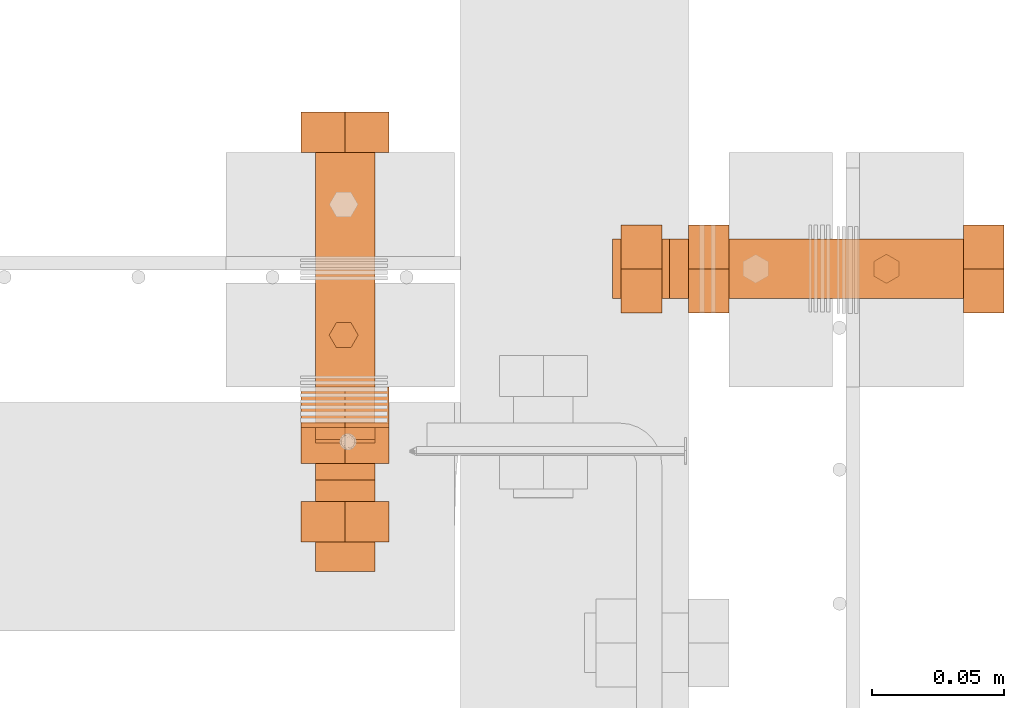
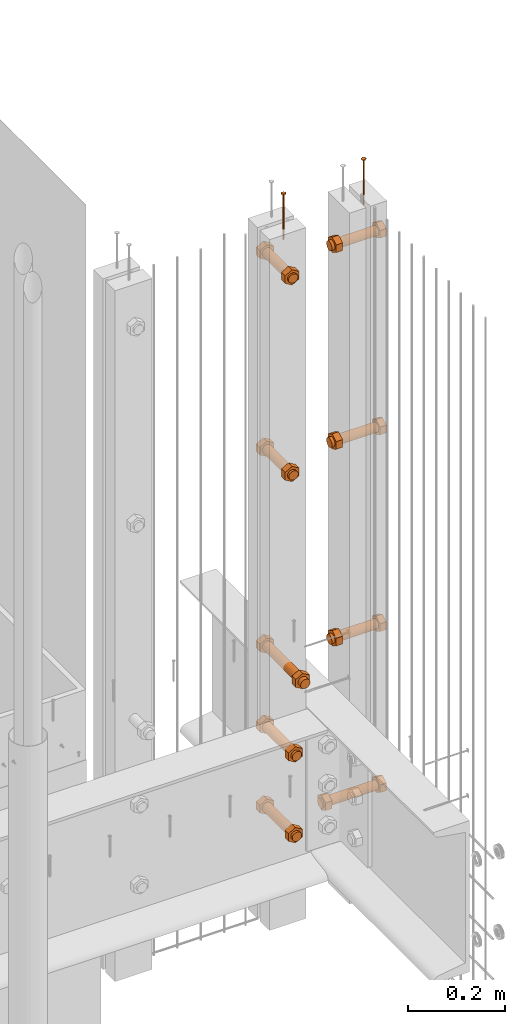
# One storey, part 24 of 44: 11 proxies.
"""IFC4 building model written with IfcOpenShell, lengths in feet."""

from ifc_helpers import new_model, entity, si_unit, converted_unit, derived_unit, direction, frame, frame_2d, origin, place, context, subcontext, project, spatial, polyline, circle, outline, extrude, source, transform, mapped, material, type_object, type_shapes, element, save


model = new_model("IFC4")

# Units and contexts
model_context = context("Model", 3, precision=0.0001, world=origin(), true_north=direction((6.12303176911189e-17, 1.0)))
body_context = subcontext(model_context, "Body", "Model", "MODEL_VIEW")
ifc_project = project(units=[converted_unit("LENGTHUNIT", "FOOT", entity("IfcRatioMeasure", 0.3048), si_unit("LENGTHUNIT", "METRE"), dimensions=[1, 0, 0, 0, 0, 0, 0]), converted_unit("AREAUNIT", "SQUARE FOOT", entity("IfcRatioMeasure", 0.09290304), si_unit("AREAUNIT", "SQUARE_METRE"), dimensions=[2, 0, 0, 0, 0, 0, 0]), converted_unit("VOLUMEUNIT", "CUBIC FOOT", entity("IfcRatioMeasure", 0.028316846592), si_unit("VOLUMEUNIT", "CUBIC_METRE"), dimensions=[3, 0, 0, 0, 0, 0, 0]), converted_unit("PLANEANGLEUNIT", "DEGREE", entity("IfcRatioMeasure", 0.0174532925199433), si_unit("PLANEANGLEUNIT", "RADIAN"), dimensions=[0, 0, 0, 0, 0, 0, 0]), si_unit("MASSUNIT", "GRAM", prefix="KILO"), derived_unit("MASSDENSITYUNIT", [(si_unit("MASSUNIT", "GRAM", prefix="KILO"), 1), (si_unit("LENGTHUNIT", "METRE"), -3)]), derived_unit("MOMENTOFINERTIAUNIT", [(si_unit("LENGTHUNIT", "METRE"), 4)]), si_unit("TIMEUNIT", "SECOND"), si_unit("FREQUENCYUNIT", "HERTZ"), si_unit("THERMODYNAMICTEMPERATUREUNIT", "DEGREE_CELSIUS"), derived_unit("THERMALTRANSMITTANCEUNIT", [(si_unit("MASSUNIT", "GRAM", prefix="KILO"), 1), (si_unit("THERMODYNAMICTEMPERATUREUNIT", "KELVIN"), -1), (si_unit("TIMEUNIT", "SECOND"), -3)]), derived_unit("VOLUMETRICFLOWRATEUNIT", [(si_unit("LENGTHUNIT", "METRE"), 3), (si_unit("TIMEUNIT", "SECOND"), -1)]), si_unit("ELECTRICCURRENTUNIT", "AMPERE"), si_unit("ELECTRICVOLTAGEUNIT", "VOLT"), si_unit("POWERUNIT", "WATT"), si_unit("FORCEUNIT", "NEWTON"), si_unit("ILLUMINANCEUNIT", "LUX"), si_unit("LUMINOUSFLUXUNIT", "LUMEN"), si_unit("LUMINOUSINTENSITYUNIT", "CANDELA"), derived_unit("USERDEFINED", [(si_unit("MASSUNIT", "GRAM", prefix="KILO"), -1), (si_unit("LENGTHUNIT", "METRE"), -2), (si_unit("TIMEUNIT", "SECOND"), 3), (si_unit("LUMINOUSFLUXUNIT", "LUMEN"), 1)]), derived_unit("LINEARVELOCITYUNIT", [(si_unit("LENGTHUNIT", "METRE"), 1), (si_unit("TIMEUNIT", "SECOND"), -1)]), si_unit("PRESSUREUNIT", "PASCAL"), derived_unit("USERDEFINED", [(si_unit("LENGTHUNIT", "METRE"), -2), (si_unit("MASSUNIT", "GRAM", prefix="KILO"), 1), (si_unit("TIMEUNIT", "SECOND"), -2)]), derived_unit("LINEARFORCEUNIT", [(si_unit("MASSUNIT", "GRAM", prefix="KILO"), 1), (si_unit("LENGTHUNIT", "METRE"), 1), (si_unit("TIMEUNIT", "SECOND"), -2), (si_unit("LENGTHUNIT", "METRE"), -1)]), derived_unit("PLANARFORCEUNIT", [(si_unit("MASSUNIT", "GRAM", prefix="KILO"), 1), (si_unit("LENGTHUNIT", "METRE"), 1), (si_unit("TIMEUNIT", "SECOND"), -2), (si_unit("LENGTHUNIT", "METRE"), -2)])], contexts=[model_context])

# Site, building, storey
site_placement = place(None, origin())
site = spatial("IfcSite", under=ifc_project, at=site_placement, CompositionType="ELEMENT")
building_placement = place(site_placement, origin())
building = spatial("IfcBuilding", under=site, at=building_placement, CompositionType="ELEMENT")
storey_placement = place(building_placement, origin())
storey = spatial("IfcBuildingStorey", under=building, at=storey_placement, CompositionType="ELEMENT", Elevation=0.0)

# Proxies
ifc_material_1 = material(Name="EXPOSED LAG BOLTS", Category="Materials")
building_element_proxy_type_1 = type_object("IfcBuildingElementProxyType", PredefinedType="NOTDEFINED", material=ifc_material_1)
shared_shape_1 = source(origin(), body_context, "Body", "SweptSolid", [
    extrude(outline(polyline([(-0.0315738428463097, -0.0546875000000126), (0.0315738428462861, -0.0546875000000126), (0.0631476856926272, 0.0), (0.0315738428463528, 0.0546874999999876), (-0.0315738428463294, 0.0546874999999873), (-0.0631476856926271, 0.0), (-0.0315738428463097, -0.0546875000000126)])), frame((0.0, 0.0, -0.425455729167055), z_axis=(0.0, 0.0, 1.0), x_axis=(0.866025403784438, -0.500000000000001, 0.0)), (0.0, 0.0, 1.0), 0.0504557291666657),
    extrude(outline(polyline([(-0.0315738428463175, -0.054687500000008), (0.0315738428463173, -0.054687500000008), (0.0631476856926152, 0.0), (0.0315738428462743, 0.0546875000000329), (-0.0315738428462739, 0.0546875000000332), (-0.0631476856926154, 0.0), (-0.0315738428463175, -0.054687500000008)])), frame((0.0, 0.0, 0.0), z_axis=(0.0, 0.0, 1.0), x_axis=(0.0, -1.0, 0.0)), (0.0, 0.0, 1.0), 0.0504557291666658),
    extrude(circle(Radius=0.0372721354166667, at=frame_2d((-3.16883874077982e-18, -6.0214796149918e-17), x_axis=(1.0, 0.0))), frame((0.0, 0.0, -0.436376009077554), z_axis=(0.0, 0.0, 1.0), x_axis=(0.0, 1.0, 0.0)), (0.0, 0.0, 1.0), 0.436376009077548),
])
type_shapes(building_element_proxy_type_1, [shared_shape_1])
proxy_1_placement = place(storey_placement, frame((1494.63395604586, 4.90491114741325, 8.9706002862303), z_axis=(1.0, 0.0, 0.0), x_axis=(0.0, 1.0, 0.0)))
element("IfcBuildingElementProxy", 1, at=proxy_1_placement, inside=storey, type_object=building_element_proxy_type_1, material=ifc_material_1, PredefinedType="NOTDEFINED", context=body_context, shape_type="MappedRepresentation", body=[
    mapped(shared_shape_1, transform((0.0, 0.0, 0.0), scale=1.0)),
])
ifc_material_2 = material(Name="TRIM HEAD SCREWS AT RAILING - EXTERIOR GRADE", Category="Materials")
building_element_proxy_type_2 = type_object("IfcBuildingElementProxyType", PredefinedType="NOTDEFINED", material=ifc_material_2)
cartesian_point_1 = entity("IfcCartesianPoint", [0.0, -0.00455729166677975, -0.374999999999898])
vertex_point_1 = entity("IfcVertexPoint", cartesian_point_1)
cartesian_point_2 = entity("IfcCartesianPoint", [0.0, 0.00455729166667765, -0.374999999999898])
vertex_point_2 = entity("IfcVertexPoint", cartesian_point_2)
cartesian_point_3 = entity("IfcCartesianPoint", [0.0, 0.0, -0.374999999999898])
ifc_direction_1 = entity("IfcDirection", [0.0, 0.0, 1.0])
ifc_direction_2 = entity("IfcDirection", [0.0, 1.0, 0.0])
edge_curve_1 = entity("IfcEdgeCurve", vertex_point_1, vertex_point_2, entity("IfcTrimmedCurve", entity("IfcCircle", entity("IfcAxis2Placement3D", cartesian_point_3, ifc_direction_1, ifc_direction_2), 0.0045572916667287), [cartesian_point_1], [cartesian_point_2], True, "CARTESIAN"), True)
vertex_point_3 = entity("IfcVertexPoint", cartesian_point_3)
ifc_direction_3 = entity("IfcDirection", [0.0, -1.0, 0.0])
edge_curve_2 = entity("IfcEdgeCurve", vertex_point_2, vertex_point_3, entity("IfcTrimmedCurve", entity("IfcLine", cartesian_point_2, entity("IfcVector", ifc_direction_3, 1.0)), [cartesian_point_2], [cartesian_point_3], True, "CARTESIAN"), True)
edge_curve_3 = entity("IfcEdgeCurve", vertex_point_3, vertex_point_1, entity("IfcTrimmedCurve", entity("IfcLine", cartesian_point_3, entity("IfcVector", ifc_direction_3, 1.0)), [cartesian_point_3], [cartesian_point_1], True, "CARTESIAN"), True)
edge_curve_4 = entity("IfcEdgeCurve", vertex_point_2, vertex_point_1, entity("IfcTrimmedCurve", entity("IfcCircle", entity("IfcAxis2Placement3D", cartesian_point_3, ifc_direction_1, ifc_direction_2), 0.0045572916667287), [cartesian_point_2], [cartesian_point_1], True, "CARTESIAN"), True)
cartesian_point_4 = entity("IfcCartesianPoint", [0.0, 0.0, -0.384114583333])
vertex_point_4 = entity("IfcVertexPoint", cartesian_point_4)
edge_curve_5 = entity("IfcEdgeCurve", vertex_point_4, vertex_point_2, entity("IfcTrimmedCurve", entity("IfcLine", cartesian_point_4, entity("IfcVector", entity("IfcDirection", [0.0, 0.447213595514596, 0.894427190992597]), 1.0)), [cartesian_point_4], [cartesian_point_2], True, "CARTESIAN"), True)
edge_curve_6 = entity("IfcEdgeCurve", vertex_point_1, vertex_point_4, entity("IfcTrimmedCurve", entity("IfcLine", cartesian_point_1, entity("IfcVector", entity("IfcDirection", [0.0, 0.447213595514579, -0.894427190992605]), 1.0)), [cartesian_point_1], [cartesian_point_4], True, "CARTESIAN"), True)
cartesian_point_5 = entity("IfcCartesianPoint", [-0.00455729166669724, 0.0, -0.374999999999898])
cartesian_point_6 = entity("IfcCartesianPoint", [0.0, 0.0, -0.379868851257523])
ifc_direction_4 = entity("IfcDirection", [0.0, 0.0, -1.0])
cartesian_point_7 = entity("IfcCartesianPoint", [-0.0156249999999625, 0.00902109795594613, 0.00260416666704037])
vertex_point_5 = entity("IfcVertexPoint", cartesian_point_7)
cartesian_point_8 = entity("IfcCartesianPoint", [-0.0156249999999625, -0.0090210979562493, 0.00260416666704046])
vertex_point_6 = entity("IfcVertexPoint", cartesian_point_8)
ifc_direction_5 = entity("IfcDirection", [0.0, -1.0, 0.0])
edge_curve_7 = entity("IfcEdgeCurve", vertex_point_5, vertex_point_6, entity("IfcTrimmedCurve", entity("IfcLine", cartesian_point_7, entity("IfcVector", ifc_direction_5, 1.0)), [cartesian_point_7], [cartesian_point_8], True, "CARTESIAN"), True)
cartesian_point_9 = entity("IfcCartesianPoint", [0.0, -0.0180421959123274, 0.0026041666670405])
vertex_point_7 = entity("IfcVertexPoint", cartesian_point_9)
edge_curve_8 = entity("IfcEdgeCurve", vertex_point_6, vertex_point_7, entity("IfcTrimmedCurve", entity("IfcLine", cartesian_point_8, entity("IfcVector", entity("IfcDirection", [0.866025403784438, -0.500000000000001, 0.0]), 1.0)), [cartesian_point_8], [cartesian_point_9], True, "CARTESIAN"), True)
cartesian_point_10 = entity("IfcCartesianPoint", [0.0156250000000786, -0.00902109795620598, 0.00260416666704046])
vertex_point_8 = entity("IfcVertexPoint", cartesian_point_10)
edge_curve_9 = entity("IfcEdgeCurve", vertex_point_7, vertex_point_8, entity("IfcTrimmedCurve", entity("IfcLine", cartesian_point_9, entity("IfcVector", entity("IfcDirection", [0.86602540378444, 0.499999999999998, 0.0]), 1.0)), [cartesian_point_9], [cartesian_point_10], True, "CARTESIAN"), True)
cartesian_point_11 = entity("IfcCartesianPoint", [0.0156250000000786, 0.00902109795590273, 0.00260416666704037])
vertex_point_9 = entity("IfcVertexPoint", cartesian_point_11)
ifc_direction_6 = entity("IfcDirection", [0.0, 1.0, 0.0])
edge_curve_10 = entity("IfcEdgeCurve", vertex_point_8, vertex_point_9, entity("IfcTrimmedCurve", entity("IfcLine", cartesian_point_10, entity("IfcVector", ifc_direction_6, 1.0)), [cartesian_point_10], [cartesian_point_11], True, "CARTESIAN"), True)
cartesian_point_12 = entity("IfcCartesianPoint", [0.0, 0.0180421959120243, 0.00260416666704032])
vertex_point_10 = entity("IfcVertexPoint", cartesian_point_12)
edge_curve_11 = entity("IfcEdgeCurve", vertex_point_9, vertex_point_10, entity("IfcTrimmedCurve", entity("IfcLine", cartesian_point_11, entity("IfcVector", entity("IfcDirection", [-0.866025403784437, 0.500000000000003, 0.0]), 1.0)), [cartesian_point_11], [cartesian_point_12], True, "CARTESIAN"), True)
edge_curve_12 = entity("IfcEdgeCurve", vertex_point_10, vertex_point_5, entity("IfcTrimmedCurve", entity("IfcLine", cartesian_point_12, entity("IfcVector", entity("IfcDirection", [-0.866025403784438, -0.500000000000001, 0.0]), 1.0)), [cartesian_point_12], [cartesian_point_7], True, "CARTESIAN"), True)
ifc_direction_7 = entity("IfcDirection", [0.0, 0.0, 1.0])
cartesian_point_13 = entity("IfcCartesianPoint", [-0.0156249999999625, 0.00902109795594612, 0.0])
vertex_point_11 = entity("IfcVertexPoint", cartesian_point_13)
cartesian_point_14 = entity("IfcCartesianPoint", [0.0, 0.0180421959120242, 0.0])
vertex_point_12 = entity("IfcVertexPoint", cartesian_point_14)
edge_curve_13 = entity("IfcEdgeCurve", vertex_point_11, vertex_point_12, entity("IfcTrimmedCurve", entity("IfcLine", cartesian_point_13, entity("IfcVector", entity("IfcDirection", [0.866025403784438, 0.500000000000001, 0.0]), 1.0)), [cartesian_point_13], [cartesian_point_14], True, "CARTESIAN"), True)
cartesian_point_15 = entity("IfcCartesianPoint", [0.0156250000000786, 0.00902109795590272, 0.0])
vertex_point_13 = entity("IfcVertexPoint", cartesian_point_15)
edge_curve_14 = entity("IfcEdgeCurve", vertex_point_12, vertex_point_13, entity("IfcTrimmedCurve", entity("IfcLine", cartesian_point_14, entity("IfcVector", entity("IfcDirection", [0.866025403784437, -0.500000000000003, 0.0]), 1.0)), [cartesian_point_14], [cartesian_point_15], True, "CARTESIAN"), True)
cartesian_point_16 = entity("IfcCartesianPoint", [0.0156250000000786, -0.00902109795620599, 0.0])
vertex_point_14 = entity("IfcVertexPoint", cartesian_point_16)
edge_curve_15 = entity("IfcEdgeCurve", vertex_point_13, vertex_point_14, entity("IfcTrimmedCurve", entity("IfcLine", cartesian_point_15, entity("IfcVector", ifc_direction_5, 1.0)), [cartesian_point_15], [cartesian_point_16], True, "CARTESIAN"), True)
cartesian_point_17 = entity("IfcCartesianPoint", [0.0, -0.0180421959123274, 0.0])
vertex_point_15 = entity("IfcVertexPoint", cartesian_point_17)
edge_curve_16 = entity("IfcEdgeCurve", vertex_point_14, vertex_point_15, entity("IfcTrimmedCurve", entity("IfcLine", cartesian_point_16, entity("IfcVector", entity("IfcDirection", [-0.86602540378444, -0.499999999999998, 0.0]), 1.0)), [cartesian_point_16], [cartesian_point_17], True, "CARTESIAN"), True)
cartesian_point_18 = entity("IfcCartesianPoint", [-0.0156249999999625, -0.00902109795624931, 0.0])
vertex_point_16 = entity("IfcVertexPoint", cartesian_point_18)
edge_curve_17 = entity("IfcEdgeCurve", vertex_point_15, vertex_point_16, entity("IfcTrimmedCurve", entity("IfcLine", cartesian_point_17, entity("IfcVector", entity("IfcDirection", [-0.866025403784438, 0.500000000000001, 0.0]), 1.0)), [cartesian_point_17], [cartesian_point_18], True, "CARTESIAN"), True)
edge_curve_18 = entity("IfcEdgeCurve", vertex_point_16, vertex_point_11, entity("IfcTrimmedCurve", entity("IfcLine", cartesian_point_18, entity("IfcVector", ifc_direction_6, 1.0)), [cartesian_point_18], [cartesian_point_13], True, "CARTESIAN"), True)
ifc_direction_8 = entity("IfcDirection", [0.0, 0.0, -1.0])
edge_curve_19 = entity("IfcEdgeCurve", vertex_point_5, vertex_point_11, entity("IfcTrimmedCurve", entity("IfcLine", cartesian_point_7, entity("IfcVector", ifc_direction_8, 1.0)), [cartesian_point_7], [cartesian_point_13], True, "CARTESIAN"), True)
edge_curve_20 = entity("IfcEdgeCurve", vertex_point_16, vertex_point_6, entity("IfcTrimmedCurve", entity("IfcLine", cartesian_point_8, entity("IfcVector", ifc_direction_7, 1.0)), [cartesian_point_18], [cartesian_point_8], True, "CARTESIAN"), True)
edge_curve_21 = entity("IfcEdgeCurve", vertex_point_15, vertex_point_7, entity("IfcTrimmedCurve", entity("IfcLine", cartesian_point_9, entity("IfcVector", ifc_direction_7, 1.0)), [cartesian_point_17], [cartesian_point_9], True, "CARTESIAN"), True)
edge_curve_22 = entity("IfcEdgeCurve", vertex_point_14, vertex_point_8, entity("IfcTrimmedCurve", entity("IfcLine", cartesian_point_10, entity("IfcVector", ifc_direction_7, 1.0)), [cartesian_point_16], [cartesian_point_10], True, "CARTESIAN"), True)
edge_curve_23 = entity("IfcEdgeCurve", vertex_point_13, vertex_point_9, entity("IfcTrimmedCurve", entity("IfcLine", cartesian_point_11, entity("IfcVector", ifc_direction_7, 1.0)), [cartesian_point_15], [cartesian_point_11], True, "CARTESIAN"), True)
edge_curve_24 = entity("IfcEdgeCurve", vertex_point_12, vertex_point_10, entity("IfcTrimmedCurve", entity("IfcLine", cartesian_point_12, entity("IfcVector", ifc_direction_7, 1.0)), [cartesian_point_14], [cartesian_point_12], True, "CARTESIAN"), True)
cartesian_point_19 = entity("IfcCartesianPoint", [0.0, -0.00455729166682102, 0.0])
vertex_point_17 = entity("IfcVertexPoint", cartesian_point_19)
cartesian_point_20 = entity("IfcCartesianPoint", [0.0, 0.00455729166651231, 0.0])
vertex_point_18 = entity("IfcVertexPoint", cartesian_point_20)
cartesian_point_21 = entity("IfcCartesianPoint", [0.0, 0.0, 0.0])
ifc_direction_9 = entity("IfcDirection", [0.0, 0.0, 1.0])
ifc_direction_10 = entity("IfcDirection", [0.0, 1.0, 0.0])
edge_curve_25 = entity("IfcEdgeCurve", vertex_point_17, vertex_point_18, entity("IfcTrimmedCurve", entity("IfcCircle", entity("IfcAxis2Placement3D", cartesian_point_21, ifc_direction_9, ifc_direction_10), 0.00455729166666667), [cartesian_point_19], [cartesian_point_20], True, "CARTESIAN"), True)
edge_curve_26 = entity("IfcEdgeCurve", vertex_point_18, vertex_point_17, entity("IfcTrimmedCurve", entity("IfcCircle", entity("IfcAxis2Placement3D", cartesian_point_21, ifc_direction_9, ifc_direction_10), 0.00455729166666667), [cartesian_point_20], [cartesian_point_19], True, "CARTESIAN"), True)
cartesian_point_22 = entity("IfcCartesianPoint", [0.0, -0.00455729166682425, -0.375000000000006])
vertex_point_19 = entity("IfcVertexPoint", cartesian_point_22)
cartesian_point_23 = entity("IfcCartesianPoint", [0.0, 0.00455729166650908, -0.375000000000006])
vertex_point_20 = entity("IfcVertexPoint", cartesian_point_23)
cartesian_point_24 = entity("IfcCartesianPoint", [0.0, 0.0, -0.375000000000006])
ifc_direction_11 = entity("IfcDirection", [0.0, 0.0, -1.0])
edge_curve_27 = entity("IfcEdgeCurve", vertex_point_19, vertex_point_20, entity("IfcTrimmedCurve", entity("IfcCircle", entity("IfcAxis2Placement3D", cartesian_point_24, ifc_direction_11, ifc_direction_10), 0.00455729166666667), [cartesian_point_22], [cartesian_point_23], True, "CARTESIAN"), True)
edge_curve_28 = entity("IfcEdgeCurve", vertex_point_20, vertex_point_19, entity("IfcTrimmedCurve", entity("IfcCircle", entity("IfcAxis2Placement3D", cartesian_point_24, ifc_direction_11, ifc_direction_10), 0.00455729166666667), [cartesian_point_23], [cartesian_point_22], True, "CARTESIAN"), True)
edge_curve_29 = entity("IfcEdgeCurve", vertex_point_17, vertex_point_19, entity("IfcTrimmedCurve", entity("IfcLine", cartesian_point_19, entity("IfcVector", ifc_direction_11, 1.0)), [cartesian_point_19], [cartesian_point_22], True, "CARTESIAN"), True)
edge_curve_30 = entity("IfcEdgeCurve", vertex_point_20, vertex_point_18, entity("IfcTrimmedCurve", entity("IfcLine", cartesian_point_20, entity("IfcVector", ifc_direction_9, 1.0)), [cartesian_point_23], [cartesian_point_20], True, "CARTESIAN"), True)
shared_shape_2 = source(origin(), body_context, "Body", "AdvancedBrep", [
    entity("IfcAdvancedBrep", entity("IfcClosedShell", [entity("IfcAdvancedFace", [entity("IfcFaceOuterBound", entity("IfcEdgeLoop", [entity("IfcOrientedEdge", None, None, edge_curve_1, True), entity("IfcOrientedEdge", None, None, edge_curve_2, True), entity("IfcOrientedEdge", None, None, edge_curve_3, True)]), True)], entity("IfcPlane", entity("IfcAxis2Placement3D", cartesian_point_3, ifc_direction_1, ifc_direction_2)), True), entity("IfcAdvancedFace", [entity("IfcFaceOuterBound", entity("IfcEdgeLoop", [entity("IfcOrientedEdge", None, None, edge_curve_4, True), entity("IfcOrientedEdge", None, None, edge_curve_3, False), entity("IfcOrientedEdge", None, None, edge_curve_2, False)]), True)], entity("IfcPlane", entity("IfcAxis2Placement3D", cartesian_point_3, ifc_direction_1, ifc_direction_2)), True), entity("IfcAdvancedFace", [entity("IfcFaceOuterBound", entity("IfcEdgeLoop", [entity("IfcOrientedEdge", None, None, edge_curve_5, True), entity("IfcOrientedEdge", None, None, edge_curve_1, False), entity("IfcOrientedEdge", None, None, edge_curve_6, True)]), True)], entity("IfcSurfaceOfRevolution", entity("IfcArbitraryOpenProfileDef", "CURVE", None, entity("IfcTrimmedCurve", entity("IfcLine", cartesian_point_4, entity("IfcVector", entity("IfcDirection", [0.447213595514577, 0.0, -0.894427190992606]), 1.0)), [cartesian_point_5], [cartesian_point_4], True, "CARTESIAN")), None, entity("IfcAxis1Placement", cartesian_point_6, ifc_direction_4)), True), entity("IfcAdvancedFace", [entity("IfcFaceOuterBound", entity("IfcEdgeLoop", [entity("IfcOrientedEdge", None, None, edge_curve_6, False), entity("IfcOrientedEdge", None, None, edge_curve_4, False), entity("IfcOrientedEdge", None, None, edge_curve_5, False)]), True)], entity("IfcSurfaceOfRevolution", entity("IfcArbitraryOpenProfileDef", "CURVE", None, entity("IfcTrimmedCurve", entity("IfcLine", cartesian_point_4, entity("IfcVector", entity("IfcDirection", [0.447213595514577, 0.0, -0.894427190992606]), 1.0)), [cartesian_point_5], [cartesian_point_4], True, "CARTESIAN")), None, entity("IfcAxis1Placement", cartesian_point_6, ifc_direction_4)), True)])),
    entity("IfcAdvancedBrep", entity("IfcClosedShell", [entity("IfcAdvancedFace", [entity("IfcFaceOuterBound", entity("IfcEdgeLoop", [entity("IfcOrientedEdge", None, None, edge_curve_7, True), entity("IfcOrientedEdge", None, None, edge_curve_8, True), entity("IfcOrientedEdge", None, None, edge_curve_9, True), entity("IfcOrientedEdge", None, None, edge_curve_10, True), entity("IfcOrientedEdge", None, None, edge_curve_11, True), entity("IfcOrientedEdge", None, None, edge_curve_12, True)]), True)], entity("IfcPlane", entity("IfcAxis2Placement3D", cartesian_point_7, ifc_direction_7, ifc_direction_5)), True), entity("IfcAdvancedFace", [entity("IfcFaceOuterBound", entity("IfcEdgeLoop", [entity("IfcOrientedEdge", None, None, edge_curve_13, True), entity("IfcOrientedEdge", None, None, edge_curve_14, True), entity("IfcOrientedEdge", None, None, edge_curve_15, True), entity("IfcOrientedEdge", None, None, edge_curve_16, True), entity("IfcOrientedEdge", None, None, edge_curve_17, True), entity("IfcOrientedEdge", None, None, edge_curve_18, True)]), True)], entity("IfcPlane", entity("IfcAxis2Placement3D", cartesian_point_13, ifc_direction_8, ifc_direction_6)), True), entity("IfcAdvancedFace", [entity("IfcFaceOuterBound", entity("IfcEdgeLoop", [entity("IfcOrientedEdge", None, None, edge_curve_7, False), entity("IfcOrientedEdge", None, None, edge_curve_19, True), entity("IfcOrientedEdge", None, None, edge_curve_18, False), entity("IfcOrientedEdge", None, None, edge_curve_20, True)]), True)], entity("IfcPlane", entity("IfcAxis2Placement3D", cartesian_point_7, entity("IfcDirection", [-1.0, 0.0, 0.0]), ifc_direction_8)), True), entity("IfcAdvancedFace", [entity("IfcFaceOuterBound", entity("IfcEdgeLoop", [entity("IfcOrientedEdge", None, None, edge_curve_8, False), entity("IfcOrientedEdge", None, None, edge_curve_20, False), entity("IfcOrientedEdge", None, None, edge_curve_17, False), entity("IfcOrientedEdge", None, None, edge_curve_21, True)]), True)], entity("IfcPlane", entity("IfcAxis2Placement3D", cartesian_point_8, entity("IfcDirection", [-0.500000000000001, -0.866025403784438, 0.0]), ifc_direction_8)), True), entity("IfcAdvancedFace", [entity("IfcFaceOuterBound", entity("IfcEdgeLoop", [entity("IfcOrientedEdge", None, None, edge_curve_9, False), entity("IfcOrientedEdge", None, None, edge_curve_21, False), entity("IfcOrientedEdge", None, None, edge_curve_16, False), entity("IfcOrientedEdge", None, None, edge_curve_22, True)]), True)], entity("IfcPlane", entity("IfcAxis2Placement3D", cartesian_point_9, entity("IfcDirection", [0.499999999999998, -0.86602540378444, 0.0]), ifc_direction_8)), True), entity("IfcAdvancedFace", [entity("IfcFaceOuterBound", entity("IfcEdgeLoop", [entity("IfcOrientedEdge", None, None, edge_curve_10, False), entity("IfcOrientedEdge", None, None, edge_curve_22, False), entity("IfcOrientedEdge", None, None, edge_curve_15, False), entity("IfcOrientedEdge", None, None, edge_curve_23, True)]), True)], entity("IfcPlane", entity("IfcAxis2Placement3D", cartesian_point_10, entity("IfcDirection", [1.0, 0.0, 0.0]), ifc_direction_8)), True), entity("IfcAdvancedFace", [entity("IfcFaceOuterBound", entity("IfcEdgeLoop", [entity("IfcOrientedEdge", None, None, edge_curve_11, False), entity("IfcOrientedEdge", None, None, edge_curve_23, False), entity("IfcOrientedEdge", None, None, edge_curve_14, False), entity("IfcOrientedEdge", None, None, edge_curve_24, True)]), True)], entity("IfcPlane", entity("IfcAxis2Placement3D", cartesian_point_11, entity("IfcDirection", [0.500000000000003, 0.866025403784437, 0.0]), ifc_direction_8)), True), entity("IfcAdvancedFace", [entity("IfcFaceOuterBound", entity("IfcEdgeLoop", [entity("IfcOrientedEdge", None, None, edge_curve_12, False), entity("IfcOrientedEdge", None, None, edge_curve_24, False), entity("IfcOrientedEdge", None, None, edge_curve_13, False), entity("IfcOrientedEdge", None, None, edge_curve_19, False)]), True)], entity("IfcPlane", entity("IfcAxis2Placement3D", cartesian_point_12, entity("IfcDirection", [-0.500000000000001, 0.866025403784438, 0.0]), ifc_direction_8)), True)])),
    entity("IfcAdvancedBrep", entity("IfcClosedShell", [entity("IfcAdvancedFace", [entity("IfcFaceOuterBound", entity("IfcEdgeLoop", [entity("IfcOrientedEdge", None, None, edge_curve_25, True), entity("IfcOrientedEdge", None, None, edge_curve_26, True)]), True)], entity("IfcPlane", entity("IfcAxis2Placement3D", cartesian_point_20, ifc_direction_9, entity("IfcDirection", [-1.0, 0.0, 0.0]))), True), entity("IfcAdvancedFace", [entity("IfcFaceOuterBound", entity("IfcEdgeLoop", [entity("IfcOrientedEdge", None, None, edge_curve_27, True), entity("IfcOrientedEdge", None, None, edge_curve_28, True)]), True)], entity("IfcPlane", entity("IfcAxis2Placement3D", cartesian_point_23, ifc_direction_11, entity("IfcDirection", [1.0, 0.0, 0.0]))), True), entity("IfcAdvancedFace", [entity("IfcFaceOuterBound", entity("IfcEdgeLoop", [entity("IfcOrientedEdge", None, None, edge_curve_25, False), entity("IfcOrientedEdge", None, None, edge_curve_29, True), entity("IfcOrientedEdge", None, None, edge_curve_28, False), entity("IfcOrientedEdge", None, None, edge_curve_30, True)]), True)], entity("IfcCylindricalSurface", entity("IfcAxis2Placement3D", cartesian_point_24, ifc_direction_9, ifc_direction_10), 0.00455729166666667), True), entity("IfcAdvancedFace", [entity("IfcFaceOuterBound", entity("IfcEdgeLoop", [entity("IfcOrientedEdge", None, None, edge_curve_26, False), entity("IfcOrientedEdge", None, None, edge_curve_30, False), entity("IfcOrientedEdge", None, None, edge_curve_27, False), entity("IfcOrientedEdge", None, None, edge_curve_29, False)]), True)], entity("IfcCylindricalSurface", entity("IfcAxis2Placement3D", cartesian_point_24, ifc_direction_9, ifc_direction_10), 0.00455729166666667), True)])),
])
type_shapes(building_element_proxy_type_2, [shared_shape_2])
proxy_2_placement = place(storey_placement, frame((1494.53823162332, 4.90491114741336, 14.1770833333334)))
element("IfcBuildingElementProxy", 2, at=proxy_2_placement, inside=storey, type_object=building_element_proxy_type_2, material=ifc_material_2, PredefinedType="NOTDEFINED", context=body_context, shape_type="MappedRepresentation", body=[
    mapped(shared_shape_2, transform((0.0, 0.0, 0.0), scale=1.0)),
])
proxy_3_placement = place(storey_placement, frame((1493.86338894197, 4.82245558853413, 14.1770833333334), z_axis=(0.0, 0.0, 1.0), x_axis=(0.0, -1.0, 0.0)))
element("IfcBuildingElementProxy", 3, at=proxy_3_placement, inside=storey, type_object=building_element_proxy_type_2, material=ifc_material_2, PredefinedType="NOTDEFINED", context=body_context, shape_type="MappedRepresentation", body=[
    mapped(shared_shape_2, transform((0.0, 0.0, 0.0), scale=1.0)),
])
building_element_proxy_type_3 = type_object("IfcBuildingElementProxyType", PredefinedType="NOTDEFINED", material=ifc_material_1)
shared_shape_3 = source(origin(), body_context, "Body", "SweptSolid", [
    extrude(outline(polyline([(-0.0315738428463097, -0.0546875000000126), (0.0315738428462861, -0.0546875000000126), (0.0631476856926272, 0.0), (0.0315738428463528, 0.0546874999999876), (-0.0315738428463294, 0.0546874999999873), (-0.0631476856926271, 0.0), (-0.0315738428463097, -0.0546875000000126)])), frame((0.0, 0.0, -0.386942113267977), z_axis=(0.0, 0.0, 1.0), x_axis=(0.866025403784438, -0.500000000000001, 0.0)), (0.0, 0.0, 1.0), 0.0504557291666657),
    extrude(outline(polyline([(-0.0315738428463175, -0.054687500000008), (0.0315738428463173, -0.054687500000008), (0.0631476856926152, 0.0), (0.0315738428462743, 0.0546875000000329), (-0.0315738428462739, 0.0546875000000332), (-0.0631476856926154, 0.0), (-0.0315738428463175, -0.054687500000008)])), frame((0.0, 0.0, 0.0), z_axis=(0.0, 0.0, 1.0), x_axis=(0.0, -1.0, 0.0)), (0.0, 0.0, 1.0), 0.0504557291666658),
    extrude(circle(Radius=0.0372721354166667, at=frame_2d((-2.80951618260646e-18, -6.0214796149918e-17), x_axis=(1.0, 0.0))), frame((0.0, 0.0, -0.407332794173276), z_axis=(0.0, 0.0, 1.0), x_axis=(0.0, 1.0, 0.0)), (0.0, 0.0, 1.0), 0.40733279417327),
])
type_shapes(building_element_proxy_type_3, [shared_shape_3])
for number, where, z_axis, x_axis in (
    (4, (1493.86520604585, 5.04953892186732, 9.63648022547445), (0.0, 1.0, 0.0), (-1.0, 0.0, 0.0)),
    (5, (1493.86520604585, 5.04953892186733, 8.97060028623031), (0.0, 1.0, 0.0), (-1.0, 0.0, 0.0)),
):
    element("IfcBuildingElementProxy", number, at=place(storey_placement, frame(where, z_axis=z_axis, x_axis=x_axis)), inside=storey, type_object=building_element_proxy_type_3, material=ifc_material_1, PredefinedType="NOTDEFINED", context=body_context, shape_type="MappedRepresentation", body=[
        mapped(shared_shape_3, transform((0.0, 0.0, 0.0), scale=1.0)),
    ])
building_element_proxy_type_4 = type_object("IfcBuildingElementProxyType", PredefinedType="NOTDEFINED", material=ifc_material_1)
shared_shape_4 = source(origin(), body_context, "Body", "SweptSolid", [
    extrude(outline(polyline([(-0.0315738428463097, -0.0546875000000126), (0.0315738428462861, -0.0546875000000126), (0.0631476856926272, 0.0), (0.0315738428463528, 0.0546874999999876), (-0.0315738428463294, 0.0546874999999873), (-0.0631476856926271, 0.0), (-0.0315738428463097, -0.0546875000000126)])), frame((0.0, 0.0, -0.484242878785972), z_axis=(0.0, 0.0, 1.0), x_axis=(0.866025403784438, -0.500000000000001, 0.0)), (0.0, 0.0, 1.0), 0.0504557291666657),
    extrude(outline(polyline([(-0.0315738428463175, -0.054687500000008), (0.0315738428463173, -0.054687500000008), (0.0631476856926152, 0.0), (0.0315738428462743, 0.0546875000000329), (-0.0315738428462739, 0.0546875000000332), (-0.0631476856926154, 0.0), (-0.0315738428463175, -0.054687500000008)])), frame((0.0, 0.0, 0.0), z_axis=(0.0, 0.0, 1.0), x_axis=(0.0, -1.0, 0.0)), (0.0, 0.0, 1.0), 0.0504557291666658),
    extrude(circle(Radius=0.0372721354166667, at=frame_2d((-3.4039800122014e-18, -6.0214796149918e-17), x_axis=(1.0, 0.0))), frame((0.0, 0.0, -0.520991011167951), z_axis=(0.0, 0.0, 1.0), x_axis=(0.0, 1.0, 0.0)), (0.0, 0.0, 1.0), 0.520991011167945),
])
type_shapes(building_element_proxy_type_4, [shared_shape_4])
proxy_4_placement = place(storey_placement, frame((1493.86520604585, 5.04953892186733, 10.3023927658464), z_axis=(0.0, 1.0, 0.0), x_axis=(-1.0, 0.0, 0.0)))
element("IfcBuildingElementProxy", 6, at=proxy_4_placement, inside=storey, type_object=building_element_proxy_type_4, material=ifc_material_1, PredefinedType="NOTDEFINED", context=body_context, shape_type="MappedRepresentation", body=[
    mapped(shared_shape_4, transform((0.0, 0.0, 0.0), scale=1.0)),
])
building_element_proxy_type_5 = type_object("IfcBuildingElementProxyType", PredefinedType="NOTDEFINED", material=ifc_material_1)
shared_shape_5 = source(origin(), body_context, "Body", "SweptSolid", [
    extrude(outline(polyline([(-0.0315738428463097, -0.0546875000000126), (0.0315738428462861, -0.0546875000000126), (0.0631476856926272, 0.0), (0.0315738428463528, 0.0546874999999876), (-0.0315738428463294, 0.0546874999999873), (-0.0631476856926271, 0.0), (-0.0315738428463097, -0.0546875000000126)])), frame((0.0, 0.0, -0.342122395833797), z_axis=(0.0, 0.0, 1.0), x_axis=(0.866025403784438, -0.500000000000001, 0.0)), (0.0, 0.0, 1.0), 0.0504557291666657),
    extrude(outline(polyline([(-0.0315738428463175, -0.054687500000008), (0.0315738428463173, -0.054687500000008), (0.0631476856926152, 0.0), (0.0315738428462743, 0.0546875000000329), (-0.0315738428462739, 0.0546875000000332), (-0.0631476856926154, 0.0), (-0.0315738428463175, -0.054687500000008)])), frame((0.0, 0.0, 0.0), z_axis=(0.0, 0.0, 1.0), x_axis=(0.0, -1.0, 0.0)), (0.0, 0.0, 1.0), 0.0504557291666658),
    extrude(circle(Radius=0.0372721354166667, at=frame_2d((-6.99018227540352e-19, -6.0214796149918e-17), x_axis=(1.0, 0.0))), frame((0.0, 0.0, -0.365196715266626), z_axis=(0.0, 0.0, 1.0), x_axis=(0.0, 1.0, 0.0)), (0.0, 0.0, 1.0), 0.36519671526662),
])
type_shapes(building_element_proxy_type_5, [shared_shape_5])
for number, where, z_axis, x_axis in (
    (7, (1494.63395604586, 4.90491114741326, 10.3023927658464), (1.0, 0.0, 0.0), (0.0, 1.0, 0.0)),
    (8, (1494.63395604586, 4.90491114741325, 11.9272380495899), (1.0, 0.0, 0.0), (0.0, 1.0, 0.0)),
    (9, (1494.63395604586, 4.90491114741325, 13.5520833333334), (1.0, 0.0, 0.0), (0.0, 1.0, 0.0)),
):
    element("IfcBuildingElementProxy", number, at=place(storey_placement, frame(where, z_axis=z_axis, x_axis=x_axis)), inside=storey, type_object=building_element_proxy_type_5, material=ifc_material_1, PredefinedType="NOTDEFINED", context=body_context, shape_type="MappedRepresentation", body=[
        mapped(shared_shape_5, transform((0.0, 0.0, 0.0), scale=1.0)),
    ])
building_element_proxy_type_6 = type_object("IfcBuildingElementProxyType", PredefinedType="NOTDEFINED", material=ifc_material_1)
shared_shape_6 = source(origin(), body_context, "Body", "SweptSolid", [
    extrude(outline(polyline([(-0.0315738428463097, -0.0546875000000126), (0.0315738428462861, -0.0546875000000126), (0.0631476856926272, 0.0), (0.0315738428463528, 0.0546874999999876), (-0.0315738428463294, 0.0546874999999873), (-0.0631476856926271, 0.0), (-0.0315738428463097, -0.0546875000000126)])), frame((0.0, 0.0, -0.342122395833737), z_axis=(0.0, 0.0, 1.0), x_axis=(0.866025403784438, -0.500000000000001, 0.0)), (0.0, 0.0, 1.0), 0.0504557291666657),
    extrude(outline(polyline([(-0.0315738428463175, -0.054687500000008), (0.0315738428463173, -0.054687500000008), (0.0631476856926152, 0.0), (0.0315738428462743, 0.0546875000000329), (-0.0315738428462739, 0.0546875000000332), (-0.0631476856926154, 0.0), (-0.0315738428463175, -0.054687500000008)])), frame((0.0, 0.0, 0.0), z_axis=(0.0, 0.0, 1.0), x_axis=(0.0, -1.0, 0.0)), (0.0, 0.0, 1.0), 0.0504557291666658),
    extrude(circle(Radius=0.0372721354166667, at=frame_2d((-2.70657840892615e-19, -6.0214796149918e-17), x_axis=(1.0, 0.0))), frame((0.0, 0.0, -0.36111899731318), z_axis=(0.0, 0.0, 1.0), x_axis=(0.0, 1.0, 0.0)), (0.0, 0.0, 1.0), 0.361118997313174),
])
type_shapes(building_element_proxy_type_6, [shared_shape_6])
proxy_5_placement = place(storey_placement, frame((1493.86520604585, 5.04953892186733, 11.92723804959), z_axis=(0.0, 1.0, 0.0), x_axis=(-1.0, 0.0, 0.0)))
element("IfcBuildingElementProxy", 10, at=proxy_5_placement, inside=storey, type_object=building_element_proxy_type_6, material=ifc_material_1, PredefinedType="NOTDEFINED", context=body_context, shape_type="MappedRepresentation", body=[
    mapped(shared_shape_6, transform((0.0, 0.0, 0.0), scale=1.0)),
])
building_element_proxy_type_7 = type_object("IfcBuildingElementProxyType", PredefinedType="NOTDEFINED", material=ifc_material_1)
shared_shape_7 = source(origin(), body_context, "Body", "SweptSolid", [
    extrude(outline(polyline([(-0.0315738428463097, -0.0546875000000126), (0.0315738428462861, -0.0546875000000126), (0.0631476856926272, 0.0), (0.0315738428463528, 0.0546874999999876), (-0.0315738428463294, 0.0546874999999873), (-0.0631476856926271, 0.0), (-0.0315738428463097, -0.0546875000000126)])), frame((0.0, 0.0, -0.342122395833722), z_axis=(0.0, 0.0, 1.0), x_axis=(0.866025403784438, -0.500000000000001, 0.0)), (0.0, 0.0, 1.0), 0.0504557291666657),
    extrude(outline(polyline([(-0.0315738428463175, -0.054687500000008), (0.0315738428463173, -0.054687500000008), (0.0631476856926152, 0.0), (0.0315738428462743, 0.0546875000000329), (-0.0315738428462739, 0.0546875000000332), (-0.0631476856926154, 0.0), (-0.0315738428463175, -0.054687500000008)])), frame((0.0, 0.0, 0.0), z_axis=(0.0, 0.0, 1.0), x_axis=(0.0, -1.0, 0.0)), (0.0, 0.0, 1.0), 0.0504557291666658),
    extrude(circle(Radius=0.0372721354166667, at=frame_2d((2.0428083246896e-18, -6.0214796149918e-17), x_axis=(1.0, 0.0))), frame((0.0, 0.0, -0.356822420865144), z_axis=(0.0, 0.0, 1.0), x_axis=(0.0, 1.0, 0.0)), (0.0, 0.0, 1.0), 0.356822420865138),
])
type_shapes(building_element_proxy_type_7, [shared_shape_7])
proxy_6_placement = place(storey_placement, frame((1493.86520604585, 5.04953892186732, 13.5520833333334), z_axis=(0.0, 1.0, 0.0), x_axis=(-1.0, 0.0, 0.0)))
element("IfcBuildingElementProxy", 11, at=proxy_6_placement, inside=storey, type_object=building_element_proxy_type_7, material=ifc_material_1, PredefinedType="NOTDEFINED", context=body_context, shape_type="MappedRepresentation", body=[
    mapped(shared_shape_7, transform((0.0, 0.0, 0.0), scale=1.0)),
])

save(model, "model.ifc")
